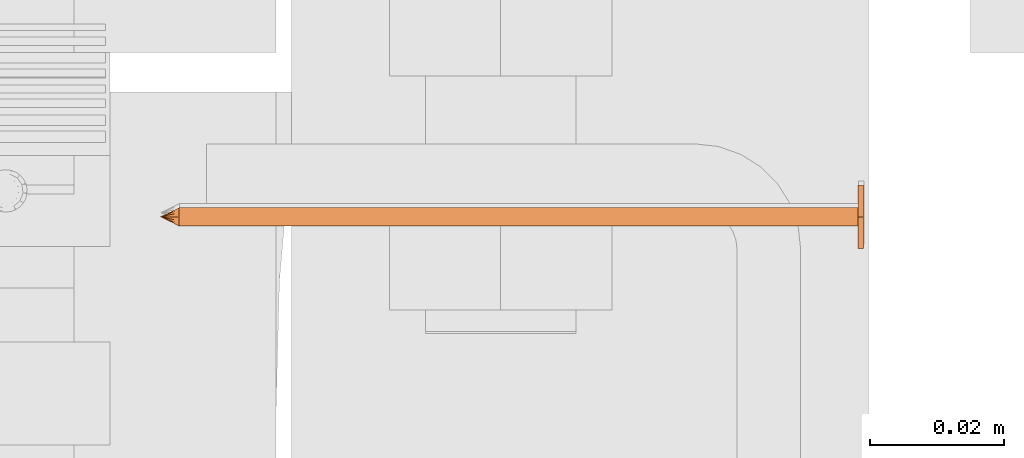
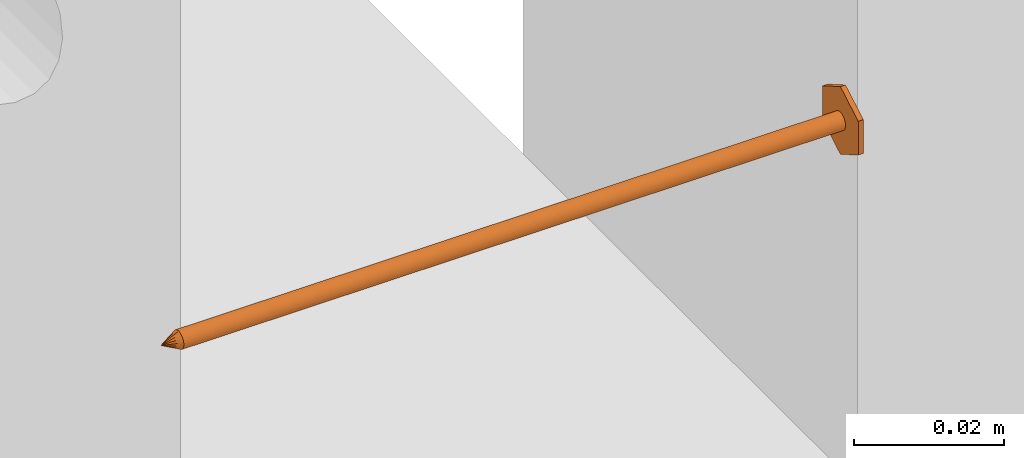
# One storey, part 25 of 44: 1 proxy.
"""IFC4 building model written with IfcOpenShell, lengths in feet."""

from ifc_helpers import new_model, entity, si_unit, converted_unit, derived_unit, direction, frame, origin, place, context, subcontext, project, spatial, source, transform, mapped, material, type_object, type_shapes, element, save


model = new_model("IFC4")

# Units and contexts
model_context = context("Model", 3, precision=0.0001, world=origin(), true_north=direction((6.12303176911189e-17, 1.0)))
body_context = subcontext(model_context, "Body", "Model", "MODEL_VIEW")
ifc_project = project(units=[converted_unit("LENGTHUNIT", "FOOT", entity("IfcRatioMeasure", 0.3048), si_unit("LENGTHUNIT", "METRE"), dimensions=[1, 0, 0, 0, 0, 0, 0]), converted_unit("AREAUNIT", "SQUARE FOOT", entity("IfcRatioMeasure", 0.09290304), si_unit("AREAUNIT", "SQUARE_METRE"), dimensions=[2, 0, 0, 0, 0, 0, 0]), converted_unit("VOLUMEUNIT", "CUBIC FOOT", entity("IfcRatioMeasure", 0.028316846592), si_unit("VOLUMEUNIT", "CUBIC_METRE"), dimensions=[3, 0, 0, 0, 0, 0, 0]), converted_unit("PLANEANGLEUNIT", "DEGREE", entity("IfcRatioMeasure", 0.0174532925199433), si_unit("PLANEANGLEUNIT", "RADIAN"), dimensions=[0, 0, 0, 0, 0, 0, 0]), si_unit("MASSUNIT", "GRAM", prefix="KILO"), derived_unit("MASSDENSITYUNIT", [(si_unit("MASSUNIT", "GRAM", prefix="KILO"), 1), (si_unit("LENGTHUNIT", "METRE"), -3)]), derived_unit("MOMENTOFINERTIAUNIT", [(si_unit("LENGTHUNIT", "METRE"), 4)]), si_unit("TIMEUNIT", "SECOND"), si_unit("FREQUENCYUNIT", "HERTZ"), si_unit("THERMODYNAMICTEMPERATUREUNIT", "DEGREE_CELSIUS"), derived_unit("THERMALTRANSMITTANCEUNIT", [(si_unit("MASSUNIT", "GRAM", prefix="KILO"), 1), (si_unit("THERMODYNAMICTEMPERATUREUNIT", "KELVIN"), -1), (si_unit("TIMEUNIT", "SECOND"), -3)]), derived_unit("VOLUMETRICFLOWRATEUNIT", [(si_unit("LENGTHUNIT", "METRE"), 3), (si_unit("TIMEUNIT", "SECOND"), -1)]), si_unit("ELECTRICCURRENTUNIT", "AMPERE"), si_unit("ELECTRICVOLTAGEUNIT", "VOLT"), si_unit("POWERUNIT", "WATT"), si_unit("FORCEUNIT", "NEWTON"), si_unit("ILLUMINANCEUNIT", "LUX"), si_unit("LUMINOUSFLUXUNIT", "LUMEN"), si_unit("LUMINOUSINTENSITYUNIT", "CANDELA"), derived_unit("USERDEFINED", [(si_unit("MASSUNIT", "GRAM", prefix="KILO"), -1), (si_unit("LENGTHUNIT", "METRE"), -2), (si_unit("TIMEUNIT", "SECOND"), 3), (si_unit("LUMINOUSFLUXUNIT", "LUMEN"), 1)]), derived_unit("LINEARVELOCITYUNIT", [(si_unit("LENGTHUNIT", "METRE"), 1), (si_unit("TIMEUNIT", "SECOND"), -1)]), si_unit("PRESSUREUNIT", "PASCAL"), derived_unit("USERDEFINED", [(si_unit("LENGTHUNIT", "METRE"), -2), (si_unit("MASSUNIT", "GRAM", prefix="KILO"), 1), (si_unit("TIMEUNIT", "SECOND"), -2)]), derived_unit("LINEARFORCEUNIT", [(si_unit("MASSUNIT", "GRAM", prefix="KILO"), 1), (si_unit("LENGTHUNIT", "METRE"), 1), (si_unit("TIMEUNIT", "SECOND"), -2), (si_unit("LENGTHUNIT", "METRE"), -1)]), derived_unit("PLANARFORCEUNIT", [(si_unit("MASSUNIT", "GRAM", prefix="KILO"), 1), (si_unit("LENGTHUNIT", "METRE"), 1), (si_unit("TIMEUNIT", "SECOND"), -2), (si_unit("LENGTHUNIT", "METRE"), -2)])], contexts=[model_context])

# Site, building, storey
site_placement = place(None, origin())
site = spatial("IfcSite", under=ifc_project, at=site_placement, CompositionType="ELEMENT")
building_placement = place(site_placement, origin())
building = spatial("IfcBuilding", under=site, at=building_placement, CompositionType="ELEMENT")
storey_placement = place(building_placement, origin())
storey = spatial("IfcBuildingStorey", under=building, at=storey_placement, CompositionType="ELEMENT", Elevation=0.0)

# Proxy
ifc_material = material(Name="TRIM HEAD SCREWS AT RAILING - EXTERIOR GRADE", Category="Materials")
building_element_proxy_type = type_object("IfcBuildingElementProxyType", PredefinedType="NOTDEFINED", material=ifc_material)
cartesian_point_1 = entity("IfcCartesianPoint", [0.0, 0.00455729166677942, -0.333333333333231])
vertex_point_1 = entity("IfcVertexPoint", cartesian_point_1)
cartesian_point_2 = entity("IfcCartesianPoint", [0.0, 0.0, -0.333333333333232])
vertex_point_2 = entity("IfcVertexPoint", cartesian_point_2)
ifc_direction_1 = entity("IfcDirection", [0.0, -1.0, 0.0])
edge_curve_1 = entity("IfcEdgeCurve", vertex_point_1, vertex_point_2, entity("IfcTrimmedCurve", entity("IfcLine", cartesian_point_1, entity("IfcVector", ifc_direction_1, 1.0)), [cartesian_point_1], [cartesian_point_2], True, "CARTESIAN"), True)
cartesian_point_3 = entity("IfcCartesianPoint", [0.0, -0.00455729166667798, -0.333333333333232])
vertex_point_3 = entity("IfcVertexPoint", cartesian_point_3)
edge_curve_2 = entity("IfcEdgeCurve", vertex_point_2, vertex_point_3, entity("IfcTrimmedCurve", entity("IfcLine", cartesian_point_2, entity("IfcVector", ifc_direction_1, 1.0)), [cartesian_point_2], [cartesian_point_3], True, "CARTESIAN"), True)
ifc_direction_2 = entity("IfcDirection", [0.0, 0.0, 1.0])
edge_curve_3 = entity("IfcEdgeCurve", vertex_point_3, vertex_point_1, entity("IfcTrimmedCurve", entity("IfcCircle", entity("IfcAxis2Placement3D", cartesian_point_2, ifc_direction_2, ifc_direction_1), 0.0045572916667287), [cartesian_point_3], [cartesian_point_1], True, "CARTESIAN"), True)
edge_curve_4 = entity("IfcEdgeCurve", vertex_point_1, vertex_point_3, entity("IfcTrimmedCurve", entity("IfcCircle", entity("IfcAxis2Placement3D", cartesian_point_2, ifc_direction_2, ifc_direction_1), 0.0045572916667287), [cartesian_point_1], [cartesian_point_3], True, "CARTESIAN"), True)
cartesian_point_4 = entity("IfcCartesianPoint", [0.0, 0.0, -0.342447916666333])
vertex_point_4 = entity("IfcVertexPoint", cartesian_point_4)
edge_curve_5 = entity("IfcEdgeCurve", vertex_point_4, vertex_point_1, entity("IfcTrimmedCurve", entity("IfcLine", cartesian_point_4, entity("IfcVector", entity("IfcDirection", [0.0, 0.447213595514579, 0.894427190992605]), 1.0)), [cartesian_point_4], [cartesian_point_1], True, "CARTESIAN"), True)
edge_curve_6 = entity("IfcEdgeCurve", vertex_point_3, vertex_point_4, entity("IfcTrimmedCurve", entity("IfcLine", cartesian_point_3, entity("IfcVector", entity("IfcDirection", [0.0, 0.447213595514596, -0.894427190992597]), 1.0)), [cartesian_point_3], [cartesian_point_4], True, "CARTESIAN"), True)
cartesian_point_5 = entity("IfcCartesianPoint", [-0.00455729166669724, 0.0, -0.333333333333231])
cartesian_point_6 = entity("IfcCartesianPoint", [0.0, 0.0, -0.338202184590857])
ifc_direction_3 = entity("IfcDirection", [0.0, 0.0, -1.0])
cartesian_point_7 = entity("IfcCartesianPoint", [-0.0156249999999625, -0.00902109795594613, 0.00260416666704037])
vertex_point_5 = entity("IfcVertexPoint", cartesian_point_7)
cartesian_point_8 = entity("IfcCartesianPoint", [0.0, -0.0180421959120243, 0.00260416666704032])
vertex_point_6 = entity("IfcVertexPoint", cartesian_point_8)
edge_curve_7 = entity("IfcEdgeCurve", vertex_point_5, vertex_point_6, entity("IfcTrimmedCurve", entity("IfcLine", cartesian_point_7, entity("IfcVector", entity("IfcDirection", [0.866025403784438, -0.500000000000001, 0.0]), 1.0)), [cartesian_point_7], [cartesian_point_8], True, "CARTESIAN"), True)
cartesian_point_9 = entity("IfcCartesianPoint", [0.0156250000000786, -0.00902109795590273, 0.00260416666704037])
vertex_point_7 = entity("IfcVertexPoint", cartesian_point_9)
edge_curve_8 = entity("IfcEdgeCurve", vertex_point_6, vertex_point_7, entity("IfcTrimmedCurve", entity("IfcLine", cartesian_point_8, entity("IfcVector", entity("IfcDirection", [0.866025403784437, 0.500000000000003, 0.0]), 1.0)), [cartesian_point_8], [cartesian_point_9], True, "CARTESIAN"), True)
cartesian_point_10 = entity("IfcCartesianPoint", [0.0156250000000786, 0.00902109795620598, 0.00260416666704046])
vertex_point_8 = entity("IfcVertexPoint", cartesian_point_10)
ifc_direction_4 = entity("IfcDirection", [0.0, 1.0, 0.0])
edge_curve_9 = entity("IfcEdgeCurve", vertex_point_7, vertex_point_8, entity("IfcTrimmedCurve", entity("IfcLine", cartesian_point_9, entity("IfcVector", ifc_direction_4, 1.0)), [cartesian_point_9], [cartesian_point_10], True, "CARTESIAN"), True)
cartesian_point_11 = entity("IfcCartesianPoint", [0.0, 0.0180421959123274, 0.0026041666670405])
vertex_point_9 = entity("IfcVertexPoint", cartesian_point_11)
edge_curve_10 = entity("IfcEdgeCurve", vertex_point_8, vertex_point_9, entity("IfcTrimmedCurve", entity("IfcLine", cartesian_point_10, entity("IfcVector", entity("IfcDirection", [-0.86602540378444, 0.499999999999998, 0.0]), 1.0)), [cartesian_point_10], [cartesian_point_11], True, "CARTESIAN"), True)
cartesian_point_12 = entity("IfcCartesianPoint", [-0.0156249999999625, 0.0090210979562493, 0.00260416666704046])
vertex_point_10 = entity("IfcVertexPoint", cartesian_point_12)
edge_curve_11 = entity("IfcEdgeCurve", vertex_point_9, vertex_point_10, entity("IfcTrimmedCurve", entity("IfcLine", cartesian_point_11, entity("IfcVector", entity("IfcDirection", [-0.866025403784438, -0.500000000000001, 0.0]), 1.0)), [cartesian_point_11], [cartesian_point_12], True, "CARTESIAN"), True)
ifc_direction_5 = entity("IfcDirection", [0.0, -1.0, 0.0])
edge_curve_12 = entity("IfcEdgeCurve", vertex_point_10, vertex_point_5, entity("IfcTrimmedCurve", entity("IfcLine", cartesian_point_12, entity("IfcVector", ifc_direction_5, 1.0)), [cartesian_point_12], [cartesian_point_7], True, "CARTESIAN"), True)
ifc_direction_6 = entity("IfcDirection", [0.0, 0.0, 1.0])
cartesian_point_13 = entity("IfcCartesianPoint", [-0.0156249999999625, -0.00902109795594612, 0.0])
vertex_point_11 = entity("IfcVertexPoint", cartesian_point_13)
cartesian_point_14 = entity("IfcCartesianPoint", [-0.0156249999999625, 0.00902109795624931, 0.0])
vertex_point_12 = entity("IfcVertexPoint", cartesian_point_14)
edge_curve_13 = entity("IfcEdgeCurve", vertex_point_11, vertex_point_12, entity("IfcTrimmedCurve", entity("IfcLine", cartesian_point_13, entity("IfcVector", ifc_direction_4, 1.0)), [cartesian_point_13], [cartesian_point_14], True, "CARTESIAN"), True)
cartesian_point_15 = entity("IfcCartesianPoint", [0.0, 0.0180421959123274, 0.0])
vertex_point_13 = entity("IfcVertexPoint", cartesian_point_15)
edge_curve_14 = entity("IfcEdgeCurve", vertex_point_12, vertex_point_13, entity("IfcTrimmedCurve", entity("IfcLine", cartesian_point_14, entity("IfcVector", entity("IfcDirection", [0.866025403784438, 0.500000000000001, 0.0]), 1.0)), [cartesian_point_14], [cartesian_point_15], True, "CARTESIAN"), True)
cartesian_point_16 = entity("IfcCartesianPoint", [0.0156250000000786, 0.00902109795620599, 0.0])
vertex_point_14 = entity("IfcVertexPoint", cartesian_point_16)
edge_curve_15 = entity("IfcEdgeCurve", vertex_point_13, vertex_point_14, entity("IfcTrimmedCurve", entity("IfcLine", cartesian_point_15, entity("IfcVector", entity("IfcDirection", [0.86602540378444, -0.499999999999998, 0.0]), 1.0)), [cartesian_point_15], [cartesian_point_16], True, "CARTESIAN"), True)
cartesian_point_17 = entity("IfcCartesianPoint", [0.0156250000000786, -0.00902109795590272, 0.0])
vertex_point_15 = entity("IfcVertexPoint", cartesian_point_17)
edge_curve_16 = entity("IfcEdgeCurve", vertex_point_14, vertex_point_15, entity("IfcTrimmedCurve", entity("IfcLine", cartesian_point_16, entity("IfcVector", ifc_direction_5, 1.0)), [cartesian_point_16], [cartesian_point_17], True, "CARTESIAN"), True)
cartesian_point_18 = entity("IfcCartesianPoint", [0.0, -0.0180421959120242, 0.0])
vertex_point_16 = entity("IfcVertexPoint", cartesian_point_18)
edge_curve_17 = entity("IfcEdgeCurve", vertex_point_15, vertex_point_16, entity("IfcTrimmedCurve", entity("IfcLine", cartesian_point_17, entity("IfcVector", entity("IfcDirection", [-0.866025403784437, -0.500000000000003, 0.0]), 1.0)), [cartesian_point_17], [cartesian_point_18], True, "CARTESIAN"), True)
edge_curve_18 = entity("IfcEdgeCurve", vertex_point_16, vertex_point_11, entity("IfcTrimmedCurve", entity("IfcLine", cartesian_point_18, entity("IfcVector", entity("IfcDirection", [-0.866025403784438, 0.500000000000001, 0.0]), 1.0)), [cartesian_point_18], [cartesian_point_13], True, "CARTESIAN"), True)
ifc_direction_7 = entity("IfcDirection", [0.0, 0.0, -1.0])
edge_curve_19 = entity("IfcEdgeCurve", vertex_point_10, vertex_point_12, entity("IfcTrimmedCurve", entity("IfcLine", cartesian_point_14, entity("IfcVector", ifc_direction_7, 1.0)), [cartesian_point_12], [cartesian_point_14], True, "CARTESIAN"), True)
edge_curve_20 = entity("IfcEdgeCurve", vertex_point_11, vertex_point_5, entity("IfcTrimmedCurve", entity("IfcLine", cartesian_point_13, entity("IfcVector", ifc_direction_6, 1.0)), [cartesian_point_13], [cartesian_point_7], True, "CARTESIAN"), True)
edge_curve_21 = entity("IfcEdgeCurve", vertex_point_9, vertex_point_13, entity("IfcTrimmedCurve", entity("IfcLine", cartesian_point_15, entity("IfcVector", ifc_direction_7, 1.0)), [cartesian_point_11], [cartesian_point_15], True, "CARTESIAN"), True)
edge_curve_22 = entity("IfcEdgeCurve", vertex_point_8, vertex_point_14, entity("IfcTrimmedCurve", entity("IfcLine", cartesian_point_16, entity("IfcVector", ifc_direction_7, 1.0)), [cartesian_point_10], [cartesian_point_16], True, "CARTESIAN"), True)
edge_curve_23 = entity("IfcEdgeCurve", vertex_point_7, vertex_point_15, entity("IfcTrimmedCurve", entity("IfcLine", cartesian_point_17, entity("IfcVector", ifc_direction_7, 1.0)), [cartesian_point_9], [cartesian_point_17], True, "CARTESIAN"), True)
edge_curve_24 = entity("IfcEdgeCurve", vertex_point_6, vertex_point_16, entity("IfcTrimmedCurve", entity("IfcLine", cartesian_point_18, entity("IfcVector", ifc_direction_7, 1.0)), [cartesian_point_8], [cartesian_point_18], True, "CARTESIAN"), True)
cartesian_point_19 = entity("IfcCartesianPoint", [0.0, 0.00455729166682102, 0.0])
vertex_point_17 = entity("IfcVertexPoint", cartesian_point_19)
cartesian_point_20 = entity("IfcCartesianPoint", [0.0, -0.00455729166651231, 0.0])
vertex_point_18 = entity("IfcVertexPoint", cartesian_point_20)
cartesian_point_21 = entity("IfcCartesianPoint", [0.0, 0.0, 0.0])
ifc_direction_8 = entity("IfcDirection", [0.0, 0.0, 1.0])
ifc_direction_9 = entity("IfcDirection", [0.0, -1.0, 0.0])
edge_curve_25 = entity("IfcEdgeCurve", vertex_point_17, vertex_point_18, entity("IfcTrimmedCurve", entity("IfcCircle", entity("IfcAxis2Placement3D", cartesian_point_21, ifc_direction_8, ifc_direction_9), 0.00455729166666667), [cartesian_point_19], [cartesian_point_20], True, "CARTESIAN"), True)
edge_curve_26 = entity("IfcEdgeCurve", vertex_point_18, vertex_point_17, entity("IfcTrimmedCurve", entity("IfcCircle", entity("IfcAxis2Placement3D", cartesian_point_21, ifc_direction_8, ifc_direction_9), 0.00455729166666667), [cartesian_point_20], [cartesian_point_19], True, "CARTESIAN"), True)
cartesian_point_22 = entity("IfcCartesianPoint", [0.0, 0.00455729166682389, -0.333333333333339])
vertex_point_19 = entity("IfcVertexPoint", cartesian_point_22)
cartesian_point_23 = entity("IfcCartesianPoint", [0.0, -0.00455729166650944, -0.333333333333339])
vertex_point_20 = entity("IfcVertexPoint", cartesian_point_23)
cartesian_point_24 = entity("IfcCartesianPoint", [0.0, 0.0, -0.333333333333339])
ifc_direction_10 = entity("IfcDirection", [0.0, 0.0, -1.0])
edge_curve_27 = entity("IfcEdgeCurve", vertex_point_19, vertex_point_20, entity("IfcTrimmedCurve", entity("IfcCircle", entity("IfcAxis2Placement3D", cartesian_point_24, ifc_direction_10, ifc_direction_9), 0.00455729166666667), [cartesian_point_22], [cartesian_point_23], True, "CARTESIAN"), True)
edge_curve_28 = entity("IfcEdgeCurve", vertex_point_20, vertex_point_19, entity("IfcTrimmedCurve", entity("IfcCircle", entity("IfcAxis2Placement3D", cartesian_point_24, ifc_direction_10, ifc_direction_9), 0.00455729166666667), [cartesian_point_23], [cartesian_point_22], True, "CARTESIAN"), True)
edge_curve_29 = entity("IfcEdgeCurve", vertex_point_18, vertex_point_20, entity("IfcTrimmedCurve", entity("IfcLine", cartesian_point_23, entity("IfcVector", ifc_direction_10, 1.0)), [cartesian_point_20], [cartesian_point_23], True, "CARTESIAN"), True)
edge_curve_30 = entity("IfcEdgeCurve", vertex_point_19, vertex_point_17, entity("IfcTrimmedCurve", entity("IfcLine", cartesian_point_22, entity("IfcVector", ifc_direction_8, 1.0)), [cartesian_point_22], [cartesian_point_19], True, "CARTESIAN"), True)
shared_shape = source(origin(), body_context, "Body", "AdvancedBrep", [
    entity("IfcAdvancedBrep", entity("IfcClosedShell", [entity("IfcAdvancedFace", [entity("IfcFaceOuterBound", entity("IfcEdgeLoop", [entity("IfcOrientedEdge", None, None, edge_curve_1, True), entity("IfcOrientedEdge", None, None, edge_curve_2, True), entity("IfcOrientedEdge", None, None, edge_curve_3, True)]), True)], entity("IfcPlane", entity("IfcAxis2Placement3D", cartesian_point_2, ifc_direction_2, ifc_direction_1)), True), entity("IfcAdvancedFace", [entity("IfcFaceOuterBound", entity("IfcEdgeLoop", [entity("IfcOrientedEdge", None, None, edge_curve_2, False), entity("IfcOrientedEdge", None, None, edge_curve_1, False), entity("IfcOrientedEdge", None, None, edge_curve_4, True)]), True)], entity("IfcPlane", entity("IfcAxis2Placement3D", cartesian_point_2, ifc_direction_2, ifc_direction_1)), True), entity("IfcAdvancedFace", [entity("IfcFaceOuterBound", entity("IfcEdgeLoop", [entity("IfcOrientedEdge", None, None, edge_curve_5, True), entity("IfcOrientedEdge", None, None, edge_curve_3, False), entity("IfcOrientedEdge", None, None, edge_curve_6, True)]), True)], entity("IfcSurfaceOfRevolution", entity("IfcArbitraryOpenProfileDef", "CURVE", None, entity("IfcTrimmedCurve", entity("IfcLine", cartesian_point_4, entity("IfcVector", entity("IfcDirection", [0.447213595514577, 0.0, -0.894427190992606]), 1.0)), [cartesian_point_5], [cartesian_point_4], True, "CARTESIAN")), None, entity("IfcAxis1Placement", cartesian_point_6, ifc_direction_3)), True), entity("IfcAdvancedFace", [entity("IfcFaceOuterBound", entity("IfcEdgeLoop", [entity("IfcOrientedEdge", None, None, edge_curve_6, False), entity("IfcOrientedEdge", None, None, edge_curve_4, False), entity("IfcOrientedEdge", None, None, edge_curve_5, False)]), True)], entity("IfcSurfaceOfRevolution", entity("IfcArbitraryOpenProfileDef", "CURVE", None, entity("IfcTrimmedCurve", entity("IfcLine", cartesian_point_4, entity("IfcVector", entity("IfcDirection", [0.447213595514577, 0.0, -0.894427190992606]), 1.0)), [cartesian_point_5], [cartesian_point_4], True, "CARTESIAN")), None, entity("IfcAxis1Placement", cartesian_point_6, ifc_direction_3)), True)])),
    entity("IfcAdvancedBrep", entity("IfcClosedShell", [entity("IfcAdvancedFace", [entity("IfcFaceOuterBound", entity("IfcEdgeLoop", [entity("IfcOrientedEdge", None, None, edge_curve_7, True), entity("IfcOrientedEdge", None, None, edge_curve_8, True), entity("IfcOrientedEdge", None, None, edge_curve_9, True), entity("IfcOrientedEdge", None, None, edge_curve_10, True), entity("IfcOrientedEdge", None, None, edge_curve_11, True), entity("IfcOrientedEdge", None, None, edge_curve_12, True)]), True)], entity("IfcPlane", entity("IfcAxis2Placement3D", cartesian_point_7, ifc_direction_6, ifc_direction_4)), True), entity("IfcAdvancedFace", [entity("IfcFaceOuterBound", entity("IfcEdgeLoop", [entity("IfcOrientedEdge", None, None, edge_curve_13, True), entity("IfcOrientedEdge", None, None, edge_curve_14, True), entity("IfcOrientedEdge", None, None, edge_curve_15, True), entity("IfcOrientedEdge", None, None, edge_curve_16, True), entity("IfcOrientedEdge", None, None, edge_curve_17, True), entity("IfcOrientedEdge", None, None, edge_curve_18, True)]), True)], entity("IfcPlane", entity("IfcAxis2Placement3D", cartesian_point_13, ifc_direction_7, ifc_direction_5)), True), entity("IfcAdvancedFace", [entity("IfcFaceOuterBound", entity("IfcEdgeLoop", [entity("IfcOrientedEdge", None, None, edge_curve_19, True), entity("IfcOrientedEdge", None, None, edge_curve_13, False), entity("IfcOrientedEdge", None, None, edge_curve_20, True), entity("IfcOrientedEdge", None, None, edge_curve_12, False)]), True)], entity("IfcPlane", entity("IfcAxis2Placement3D", cartesian_point_7, entity("IfcDirection", [-1.0, 0.0, 0.0]), ifc_direction_7)), True), entity("IfcAdvancedFace", [entity("IfcFaceOuterBound", entity("IfcEdgeLoop", [entity("IfcOrientedEdge", None, None, edge_curve_21, True), entity("IfcOrientedEdge", None, None, edge_curve_14, False), entity("IfcOrientedEdge", None, None, edge_curve_19, False), entity("IfcOrientedEdge", None, None, edge_curve_11, False)]), True)], entity("IfcPlane", entity("IfcAxis2Placement3D", cartesian_point_12, entity("IfcDirection", [-0.500000000000001, 0.866025403784438, 0.0]), ifc_direction_7)), True), entity("IfcAdvancedFace", [entity("IfcFaceOuterBound", entity("IfcEdgeLoop", [entity("IfcOrientedEdge", None, None, edge_curve_22, True), entity("IfcOrientedEdge", None, None, edge_curve_15, False), entity("IfcOrientedEdge", None, None, edge_curve_21, False), entity("IfcOrientedEdge", None, None, edge_curve_10, False)]), True)], entity("IfcPlane", entity("IfcAxis2Placement3D", cartesian_point_11, entity("IfcDirection", [0.499999999999998, 0.86602540378444, 0.0]), ifc_direction_7)), True), entity("IfcAdvancedFace", [entity("IfcFaceOuterBound", entity("IfcEdgeLoop", [entity("IfcOrientedEdge", None, None, edge_curve_23, True), entity("IfcOrientedEdge", None, None, edge_curve_16, False), entity("IfcOrientedEdge", None, None, edge_curve_22, False), entity("IfcOrientedEdge", None, None, edge_curve_9, False)]), True)], entity("IfcPlane", entity("IfcAxis2Placement3D", cartesian_point_10, entity("IfcDirection", [1.0, 0.0, 0.0]), ifc_direction_7)), True), entity("IfcAdvancedFace", [entity("IfcFaceOuterBound", entity("IfcEdgeLoop", [entity("IfcOrientedEdge", None, None, edge_curve_24, True), entity("IfcOrientedEdge", None, None, edge_curve_17, False), entity("IfcOrientedEdge", None, None, edge_curve_23, False), entity("IfcOrientedEdge", None, None, edge_curve_8, False)]), True)], entity("IfcPlane", entity("IfcAxis2Placement3D", cartesian_point_9, entity("IfcDirection", [0.500000000000003, -0.866025403784437, 0.0]), ifc_direction_7)), True), entity("IfcAdvancedFace", [entity("IfcFaceOuterBound", entity("IfcEdgeLoop", [entity("IfcOrientedEdge", None, None, edge_curve_20, False), entity("IfcOrientedEdge", None, None, edge_curve_18, False), entity("IfcOrientedEdge", None, None, edge_curve_24, False), entity("IfcOrientedEdge", None, None, edge_curve_7, False)]), True)], entity("IfcPlane", entity("IfcAxis2Placement3D", cartesian_point_8, entity("IfcDirection", [-0.500000000000001, -0.866025403784438, 0.0]), ifc_direction_7)), True)])),
    entity("IfcAdvancedBrep", entity("IfcClosedShell", [entity("IfcAdvancedFace", [entity("IfcFaceOuterBound", entity("IfcEdgeLoop", [entity("IfcOrientedEdge", None, None, edge_curve_25, True), entity("IfcOrientedEdge", None, None, edge_curve_26, True)]), True)], entity("IfcPlane", entity("IfcAxis2Placement3D", cartesian_point_20, ifc_direction_8, entity("IfcDirection", [-1.0, 0.0, 0.0]))), True), entity("IfcAdvancedFace", [entity("IfcFaceOuterBound", entity("IfcEdgeLoop", [entity("IfcOrientedEdge", None, None, edge_curve_27, True), entity("IfcOrientedEdge", None, None, edge_curve_28, True)]), True)], entity("IfcPlane", entity("IfcAxis2Placement3D", cartesian_point_23, ifc_direction_10, entity("IfcDirection", [1.0, 0.0, 0.0]))), True), entity("IfcAdvancedFace", [entity("IfcFaceOuterBound", entity("IfcEdgeLoop", [entity("IfcOrientedEdge", None, None, edge_curve_29, True), entity("IfcOrientedEdge", None, None, edge_curve_27, False), entity("IfcOrientedEdge", None, None, edge_curve_30, True), entity("IfcOrientedEdge", None, None, edge_curve_26, False)]), True)], entity("IfcCylindricalSurface", entity("IfcAxis2Placement3D", cartesian_point_24, ifc_direction_8, ifc_direction_9), 0.00455729166666667), True), entity("IfcAdvancedFace", [entity("IfcFaceOuterBound", entity("IfcEdgeLoop", [entity("IfcOrientedEdge", None, None, edge_curve_30, False), entity("IfcOrientedEdge", None, None, edge_curve_28, False), entity("IfcOrientedEdge", None, None, edge_curve_29, False), entity("IfcOrientedEdge", None, None, edge_curve_25, False)]), True)], entity("IfcCylindricalSurface", entity("IfcAxis2Placement3D", cartesian_point_24, ifc_direction_8, ifc_direction_9), 0.00455729166666667), True)])),
])
type_shapes(building_element_proxy_type, [shared_shape])
proxy_placement = place(storey_placement, frame((1494.28712595006, 4.67721920443243, 10.1148601647184), z_axis=(1.0, 0.0, 0.0), x_axis=(0.0, 1.0, 0.0)))
element("IfcBuildingElementProxy", 1, at=proxy_placement, inside=storey, type_object=building_element_proxy_type, material=ifc_material, PredefinedType="NOTDEFINED", context=body_context, shape_type="MappedRepresentation", body=[
    mapped(shared_shape, transform((0.0, 0.0, 0.0), scale=1.0)),
])

save(model, "model.ifc")
